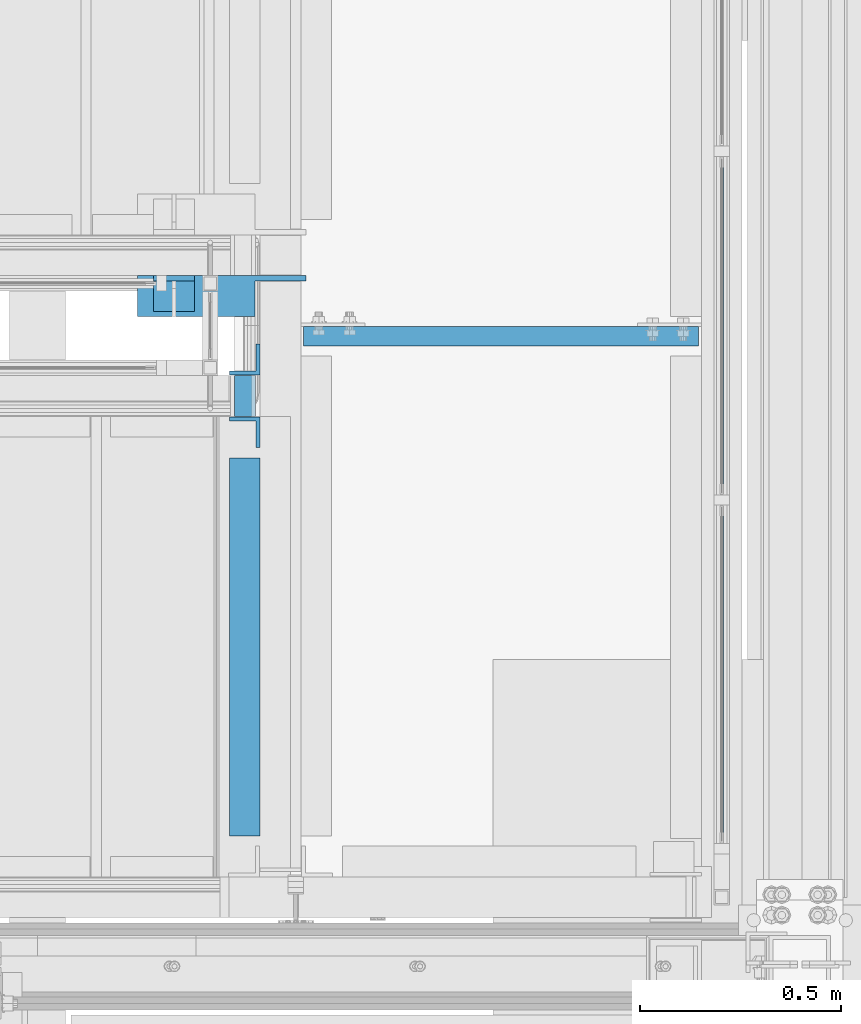
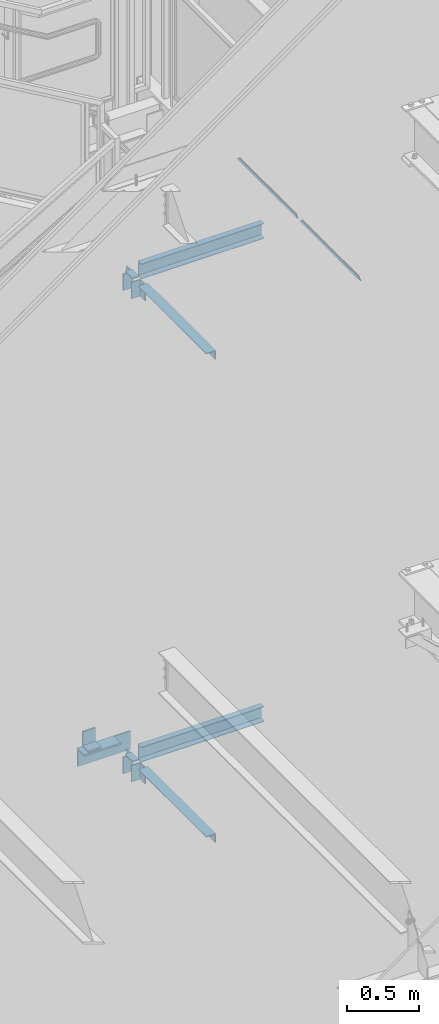
# One storey, part 922 of 1179: 14 beams, 9 elements without a shape of their own.
"""IFC2X3 building model written with IfcOpenShell, lengths in millimetres."""

from ifc_helpers import new_model, si_unit, frame, origin_with_axes, place, context, subcontext, project, spatial, faceted_brep, material, type_object, element, aggregate, save


model = new_model("IFC2X3")

# Units and contexts
model_context = context("Model", 3, precision=1e-05, world=origin_with_axes())
body_context = subcontext(model_context, "Body", "Model", "MODEL_VIEW")
ifc_project = project(units=[si_unit("LENGTHUNIT", "METRE", prefix="MILLI"), si_unit("AREAUNIT", "SQUARE_METRE"), si_unit("VOLUMEUNIT", "CUBIC_METRE"), si_unit("MASSUNIT", "GRAM", prefix="KILO"), si_unit("TIMEUNIT", "SECOND"), si_unit("PLANEANGLEUNIT", "RADIAN"), si_unit("SOLIDANGLEUNIT", "STERADIAN"), si_unit("THERMODYNAMICTEMPERATUREUNIT", "DEGREE_CELSIUS"), si_unit("LUMINOUSINTENSITYUNIT", "LUMEN")], contexts=[model_context])

# Site, building, storey
site_placement = place(None, origin_with_axes())
site = spatial("IfcSite", under=ifc_project, at=site_placement, CompositionType="ELEMENT")
building_placement = place(site_placement, origin_with_axes())
building = spatial("IfcBuilding", under=site, at=building_placement, Name="Undefined", CompositionType="ELEMENT")
storey_placement = place(building_placement, origin_with_axes())
storey = spatial("IfcBuildingStorey", under=building, at=storey_placement, Name="Undefined", CompositionType="ELEMENT", Elevation=0.0)

# Assembly, beams
assembly_1_placement = place(storey_placement, origin_with_axes())
assembly_1 = element("IfcElementAssembly", 1, at=assembly_1_placement, inside=storey, Name="GUARDRAIL", AssemblyPlace="NOTDEFINED", PredefinedType="RIGID_FRAME")
ifc_material_1 = material(Name="STEEL/BUY-OUT")
beam_type_1 = type_object("IfcBeamType", PredefinedType="NOTDEFINED")
beam_1_placement = place(assembly_1_placement, frame((24110.9502052178, 39576.2424575509, 6357.93749958167), z_axis=(0.0, 1.0, 0.0), x_axis=(0.0, 0.0, -1.0)))
beam_1 = element("IfcBeam", 2, at=beam_1_placement, type_object=beam_type_1, material=ifc_material_1, Name="U-EDGE", context=body_context, shape_type="Brep", body=[
    faceted_brep([(-5.45696821063757e-11, -4.76236513509502, -392.906500000157), (22.2249999999613, -4.76236513509502, -415.131500000178), (22.2249999999794, -1.58750000000146, -415.131500000192), (0.0, -1.58750000000146, -392.906500000216), (0.0, 1.58750000000146, -392.906500000216), (25.3999999999969, 1.58750000000146, -418.306499999999), (25.3999999999423, -7.93736513509793, -418.306499999999), (-5.45696821063757e-11, -7.93736513509793, -392.906500000157), (25.3999999999423, -7.93736513509793, 418.306499999999), (-5.45696821063757e-11, -7.93736513509793, 392.906500780409), (-5.45696821063757e-11, -4.76236513509502, 392.906500780409), (22.2249999999613, -4.76236513509502, 415.131500780422), (22.2249999999794, -1.58750000000146, 415.131500780437), (0.0, -1.58750000000146, 392.90650078046), (0.0, 1.58750000000146, 392.90650078046), (25.3999999999969, 1.58750000000146, 418.306499999999)], [[[0, 1, 2, 3, 4, 5, 6, 7]], [[7, 6, 8, 9]], [[0, 7, 9, 10]], [[1, 0, 10, 11]], [[2, 1, 11, 12]], [[3, 2, 12, 13]], [[4, 3, 13, 14]], [[5, 4, 14, 15]], [[6, 5, 15, 8]], [[14, 13, 12, 11, 10, 9, 8, 15]]]),
])
beam_2_placement = place(assembly_1_placement, frame((24110.9502052178, 38710.5257908844, 6357.93750006389), z_axis=(0.0, 1.0, 0.0), x_axis=(0.0, 0.0, -1.0)))
beam_2 = element("IfcBeam", 3, at=beam_2_placement, type_object=beam_type_1, material=ifc_material_1, Name="U-EDGE", context=body_context, shape_type="Brep", body=[
    faceted_brep([(-5.45696821063757e-11, -4.76236513509502, -392.906500000157), (22.2249999999613, -4.76236513509502, -415.131500000178), (22.2249999999794, -1.58750000000146, -415.131500000192), (0.0, -1.58750000000146, -392.906500000216), (0.0, 1.58750000000146, -392.906500000216), (25.3999999999969, 1.58750000000146, -418.306499999999), (25.3999999999423, -7.93736513509793, -418.306499999999), (-5.45696821063757e-11, -7.93736513509793, -392.906500000157), (25.3999999999423, -7.93736513509793, 418.306499999999), (-5.45696821063757e-11, -7.93736513509793, 392.906500780409), (-5.45696821063757e-11, -4.76236513509502, 392.906500780409), (22.2249999999613, -4.76236513509502, 415.131500780422), (22.2249999999794, -1.58750000000146, 415.131500780437), (0.0, -1.58750000000146, 392.90650078046), (0.0, 1.58750000000146, 392.90650078046), (25.3999999999969, 1.58750000000146, 418.306499999999)], [[[0, 1, 2, 3, 4, 5, 6, 7]], [[7, 6, 8, 9]], [[0, 7, 9, 10]], [[1, 0, 10, 11]], [[2, 1, 11, 12]], [[3, 2, 12, 13]], [[4, 3, 13, 14]], [[5, 4, 14, 15]], [[6, 5, 15, 8]], [[14, 13, 12, 11, 10, 9, 8, 15]]]),
])
aggregate(assembly_1, [beam_1, beam_2])

assembly_2_placement = place(storey_placement, origin_with_axes())
assembly_2 = element("IfcElementAssembly", 4, at=assembly_2_placement, inside=storey, Name="BEAM", AssemblyPlace="NOTDEFINED", PredefinedType="RIGID_FRAME")
ifc_material_2 = material(Name="STEEL/A36")
beam_type_2 = type_object("IfcBeamType", Name="L3X3X3/8", PredefinedType="NOTDEFINED")
beam_3_placement = place(assembly_2_placement, frame((22929.8500003381, 39311.2624999755, 6112.47000099707), z_axis=(0.0, -1.0, 0.0), x_axis=(0.0, 0.0, -1.0)))
beam_3 = element("IfcBeam", 5, at=beam_3_placement, type_object=beam_type_2, material=ifc_material_2, Name="ANGLE", ObjectType="L3X3X3/8", context=body_context, shape_type="Brep", body=[
    faceted_brep([(0.0, 38.0999999999985, -38.0999999999999), (0.0, 38.0999999999985, 38.0999999999999), (139.7, 38.0999999999985, 38.0999999999985), (139.7, 38.0999999999985, -38.0999999999985), (0.0, 28.5750000000007, 38.0999999999999), (139.7, 28.5750000000007, 38.0999999999985), (0.0, 28.5750000000007, -28.575), (139.7, 28.5750000000007, -28.5749999999971), (0.0, -38.0999999999985, -28.575), (139.7, -38.0999999999985, -28.5749999999971), (0.0, -38.0999999999985, -38.0999999999999), (139.7, -38.0999999999985, -38.0999999999985)], [[[0, 1, 2, 3]], [[1, 4, 5, 2]], [[4, 6, 7, 5]], [[6, 8, 9, 7]], [[8, 10, 11, 9]], [[10, 0, 3, 11]], [[5, 7, 9, 11, 3, 2]], [[10, 8, 6, 4, 1, 0]]]),
])
beam_4_placement = place(assembly_2_placement, frame((22929.6205004791, 39492.2375000293, 6112.47000099708), z_axis=(-1.0, 0.0, 0.0), x_axis=(0.0, 0.0, -1.0)))
beam_4 = element("IfcBeam", 6, at=beam_4_placement, type_object=beam_type_2, material=ifc_material_2, Name="ANGLE", ObjectType="L3X3X3/8", context=body_context, shape_type="Brep", body=[
    faceted_brep([(0.0, 38.0999999999985, -38.0999999999999), (0.0, 38.0999999999985, 38.0999999999999), (139.7, 38.0999999999985, 38.0999999999985), (139.7, 38.0999999999985, -38.0999999999985), (0.0, 28.5750000000007, 38.0999999999999), (139.7, 28.5750000000007, 38.0999999999985), (0.0, 28.5750000000007, -28.575), (139.7, 28.5750000000007, -28.5749999999971), (0.0, -38.0999999999985, -28.575), (139.7, -38.0999999999985, -28.5749999999971), (0.0, -38.0999999999985, -38.0999999999999), (139.7, -38.0999999999985, -38.0999999999985)], [[[0, 1, 2, 3]], [[1, 4, 5, 2]], [[4, 6, 7, 5]], [[6, 8, 9, 7]], [[8, 10, 11, 9]], [[10, 0, 3, 11]], [[5, 7, 9, 11, 3, 2]], [[10, 8, 6, 4, 1, 0]]]),
])

assembly_3_placement = place(storey_placement, origin_with_axes())
assembly_3 = element("IfcElementAssembly", 7, at=assembly_3_placement, inside=storey, Name="BEAM", AssemblyPlace="NOTDEFINED", PredefinedType="RIGID_FRAME")
beam_5_placement = place(assembly_3_placement, frame((22929.8500003381, 39311.2624999755, 2038.94531200001), z_axis=(0.0, -1.0, 0.0), x_axis=(0.0, 0.0, -1.0)))
beam_5 = element("IfcBeam", 8, at=beam_5_placement, type_object=beam_type_2, material=ifc_material_2, Name="ANGLE", ObjectType="L3X3X3/8", context=body_context, shape_type="Brep", body=[
    faceted_brep([(0.0, 38.0999999999985, -38.0999999999999), (0.0, 38.0999999999985, 38.0999999999999), (139.7, 38.0999999999985, 38.0999999999985), (139.7, 38.0999999999985, -38.0999999999985), (0.0, 28.5750000000007, 38.0999999999999), (139.7, 28.5750000000007, 38.0999999999985), (0.0, 28.5750000000007, -28.575), (139.7, 28.5750000000007, -28.5749999999971), (0.0, -38.0999999999985, -28.575), (139.7, -38.0999999999985, -28.5749999999971), (0.0, -38.0999999999985, -38.0999999999999), (139.7, -38.0999999999985, -38.0999999999985)], [[[0, 1, 2, 3]], [[1, 4, 5, 2]], [[4, 6, 7, 5]], [[6, 8, 9, 7]], [[8, 10, 11, 9]], [[10, 0, 3, 11]], [[5, 7, 9, 11, 3, 2]], [[10, 8, 6, 4, 1, 0]]]),
])
beam_6_placement = place(assembly_3_placement, frame((22929.8500003381, 39492.2375000046, 2038.94531200002), z_axis=(-1.0, 0.0, 0.0), x_axis=(0.0, 0.0, -1.0)))
beam_6 = element("IfcBeam", 9, at=beam_6_placement, type_object=beam_type_2, material=ifc_material_2, Name="ANGLE", ObjectType="L3X3X3/8", context=body_context, shape_type="Brep", body=[
    faceted_brep([(0.0, 38.0999999999985, -38.0999999999999), (0.0, 38.0999999999985, 38.0999999999999), (139.7, 38.0999999999985, 38.0999999999985), (139.7, 38.0999999999985, -38.0999999999985), (0.0, 28.5750000000007, 38.0999999999999), (139.7, 28.5750000000007, 38.0999999999985), (0.0, 28.5750000000007, -28.575), (139.7, 28.5750000000007, -28.5749999999971), (0.0, -38.0999999999985, -28.575), (139.7, -38.0999999999985, -28.5749999999971), (0.0, -38.0999999999985, -38.0999999999999), (139.7, -38.0999999999985, -38.0999999999985)], [[[0, 1, 2, 3]], [[1, 4, 5, 2]], [[4, 6, 7, 5]], [[6, 8, 9, 7]], [[8, 10, 11, 9]], [[10, 0, 3, 11]], [[5, 7, 9, 11, 3, 2]], [[10, 8, 6, 4, 1, 0]]]),
])

# Assembly, beam
assembly_4_placement = place(storey_placement, origin_with_axes())
assembly_4 = element("IfcElementAssembly", 10, at=assembly_4_placement, inside=storey, Name="ANGLE", AssemblyPlace="NOTDEFINED", PredefinedType="RIGID_FRAME")
beam_type_3 = type_object("IfcBeamType", Name="L5X3-1/2X1/2", PredefinedType="NOTDEFINED")
beam_7_placement = place(assembly_4_placement, frame((22703.2939505092, 39655.7500000355, 2115.145312), z_axis=(0.0, 0.0, 1.0), x_axis=(1.0, 0.0, 0.0)))
beam_7 = element("IfcBeam", 11, at=beam_7_placement, type_object=beam_type_3, material=ifc_material_2, Name="ANGLE", ObjectType="L5X3-1/2X1/2", context=body_context, shape_type="Brep", body=[
    faceted_brep([(0.0, 44.4499999999971, -63.5), (0.0, 44.4499999999971, 63.5), (101.599999999999, 44.4499999999971, 63.5), (101.599999999999, 44.4499999999971, -63.5), (0.0, 31.75, 63.5), (101.599999999999, 31.75, 63.5), (0.0, 31.75, -50.8000000000002), (101.599999999999, 31.75, -50.8000000000002), (0.0, -44.4499999999971, -50.8000000000002), (101.599999999999, -44.4499999999971, -50.8000000000002), (0.0, -44.4499999999971, -63.5), (101.599999999999, -44.4499999999971, -63.5)], [[[0, 1, 2, 3]], [[1, 4, 5, 2]], [[4, 6, 7, 5]], [[6, 8, 9, 7]], [[8, 10, 11, 9]], [[10, 0, 3, 11]], [[5, 7, 9, 11, 3, 2]], [[10, 8, 6, 4, 1, 0]]]),
])
aggregate(assembly_4, [beam_7])

assembly_5_placement = place(storey_placement, origin_with_axes())
assembly_5 = element("IfcElementAssembly", 12, at=assembly_5_placement, inside=storey, Name="ANGLE", AssemblyPlace="NOTDEFINED", PredefinedType="RIGID_FRAME")
beam_type_4 = type_object("IfcBeamType", Name="L6X4X1/2", PredefinedType="NOTDEFINED")
beam_8_placement = place(assembly_5_placement, frame((23082.2500006927, 39649.3999999582, 1975.445312), z_axis=(0.0, 0.0, -1.0), x_axis=(-1.0, 0.0, 0.0)))
beam_8 = element("IfcBeam", 13, at=beam_8_placement, type_object=beam_type_4, material=ifc_material_2, Name="ANGLE", ObjectType="L6X4X1/2", context=body_context, shape_type="Brep", body=[
    faceted_brep([(0.0, 38.0999999999985, -63.5), (0.0, 38.0999999999985, -76.1999999999998), (127.0, 38.0999999999985, -76.1999999999998), (127.0, 38.0999999999985, -63.5), (127.0, -50.8000000000029, -63.5), (127.0, -50.8000000000029, -76.1999999999998), (419.099999999999, -50.8000000000029, -76.1999999999998), (419.099999999999, -50.8000000000029, -63.5), (0.0, 50.8000000000029, -76.1999999999998), (419.099999999999, 50.8000000000029, -76.1999999999998), (0.0, 38.0999999999985, 76.1999999999998), (0.0, 50.8000000000029, 76.1999999999998), (127.0, 38.0999999999985, 76.1999999999998), (419.099999999999, 38.0999999999985, 76.1999999999998), (419.099999999999, 50.8000000000029, 76.1999999999998), (419.099999999999, 38.0999999999985, -63.5)], [[[0, 1, 2, 3]], [[4, 3, 2, 5]], [[6, 7, 4, 5]], [[1, 8, 9, 6, 5, 2]], [[10, 11, 8, 1, 0]], [[11, 10, 12, 13, 14]], [[8, 11, 14, 9]], [[13, 15, 7, 6, 9, 14]], [[12, 10, 0, 3, 15, 13]], [[7, 15, 3, 4]]]),
])
aggregate(assembly_5, [beam_8])

# Beam
beam_type_5 = type_object("IfcBeamType", Name="L3X3X1/4", PredefinedType="NOTDEFINED")
beam_9_placement = place(assembly_2_placement, frame((22929.8500003381, 38309.5499999763, 6099.77000099707), z_axis=(0.0, 0.0, -1.0), x_axis=(0.0, 1.0, 0.0)))
beam_9 = element("IfcBeam", 14, at=beam_9_placement, type_object=beam_type_5, material=ifc_material_2, Name="ANGLE", ObjectType="L3X3X1/4", context=body_context, shape_type="Brep", body=[
    faceted_brep([(0.0, 38.0999999999985, -38.0999999999999), (0.0, 38.0999999999985, 38.0999999999999), (938.212500058144, 38.0999999999985, 38.1000000000004), (938.212500058144, 38.0999999999985, -38.1000000000004), (0.0, 31.75, 38.1000000000004), (938.212500058144, 31.75, 38.1000000000004), (0.0, 31.75, -31.75), (938.212500058144, 31.75, -31.75), (0.0, -38.0999999999985, -31.75), (938.212500058144, -38.0999999999985, -31.75), (0.0, -38.0999999999985, -38.0999999999999), (938.212500058144, -38.0999999999985, -38.1000000000004)], [[[0, 1, 2, 3]], [[1, 4, 5, 2]], [[4, 6, 7, 5]], [[6, 8, 9, 7]], [[8, 10, 11, 9]], [[10, 0, 3, 11]], [[5, 7, 9, 11, 3, 2]], [[10, 8, 6, 4, 1, 0]]]),
])

aggregate(assembly_2, [beam_9, beam_3, beam_4])

beam_10_placement = place(assembly_3_placement, frame((22929.8500003381, 38309.5499999763, 2026.245312), z_axis=(0.0, 0.0, -1.0), x_axis=(0.0, 1.0, 0.0)))
beam_10 = element("IfcBeam", 15, at=beam_10_placement, type_object=beam_type_5, material=ifc_material_2, Name="ANGLE", ObjectType="L3X3X1/4", context=body_context, shape_type="Brep", body=[
    faceted_brep([(0.0, 38.0999999999985, -38.0999999999999), (0.0, 38.0999999999985, 38.0999999999999), (938.212500058144, 38.0999999999985, 38.1000000000004), (938.212500058144, 38.0999999999985, -38.1000000000004), (0.0, 31.75, 38.1000000000004), (938.212500058144, 31.75, 38.1000000000004), (0.0, 31.75, -31.75), (938.212500058144, 31.75, -31.75), (0.0, -38.0999999999985, -31.75), (938.212500058144, -38.0999999999985, -31.75), (0.0, -38.0999999999985, -38.0999999999999), (938.212500058144, -38.0999999999985, -38.1000000000004)], [[[0, 1, 2, 3]], [[1, 4, 5, 2]], [[4, 6, 7, 5]], [[6, 8, 9, 7]], [[8, 10, 11, 9]], [[10, 0, 3, 11]], [[5, 7, 9, 11, 3, 2]], [[10, 8, 6, 4, 1, 0]]]),
])

aggregate(assembly_3, [beam_10, beam_5, beam_6])

# Assembly, beam
assembly_6_placement = place(storey_placement, origin_with_axes())
assembly_6 = element("IfcElementAssembly", 16, at=assembly_6_placement, inside=storey, Name="STAIR", AssemblyPlace="NOTDEFINED", PredefinedType="RIGID_FRAME")
beam_type_6 = type_object("IfcBeamType", PredefinedType="NOTDEFINED")
beam_11_placement = place(assembly_6_placement, frame((22956.8374995998, 39401.7499999899, 6133.10750099708), z_axis=(0.0, -1.0, 0.0), x_axis=(-1.0, 0.0, 0.0)))
beam_11 = element("IfcBeam", 17, at=beam_11_placement, type_object=beam_type_6, material=ifc_material_2, Name="PLATE", context=body_context, shape_type="Brep", body=[
    faceted_brep([(0.0, 4.76249999999982, -50.7999999999993), (0.0, 4.76249999999982, 50.7999999999993), (52.3874995939332, 4.76249999999982, 50.8000000000029), (52.3874995939332, 4.76249999999982, -50.8000000000029), (0.0, -4.76249999999982, 50.7999999999993), (52.3874995939332, -4.76249999999982, 50.8000000000029), (0.0, -4.76249999999982, -50.7999999999993), (52.3874995939332, -4.76249999999982, -50.8000000000029)], [[[0, 1, 2, 3]], [[1, 4, 5, 2]], [[4, 6, 7, 5]], [[6, 0, 3, 7]], [[5, 7, 3, 2]], [[6, 4, 1, 0]]]),
])
aggregate(assembly_6, [beam_11])

assembly_7_placement = place(storey_placement, origin_with_axes())
assembly_7 = element("IfcElementAssembly", 18, at=assembly_7_placement, inside=storey, Name="STAIR", AssemblyPlace="NOTDEFINED", PredefinedType="RIGID_FRAME")
beam_12_placement = place(assembly_7_placement, frame((22956.8374998743, 39401.7499999987, 2059.58281200001), z_axis=(0.0, -1.0, 0.0), x_axis=(-1.0, 0.0, 0.0)))
beam_12 = element("IfcBeam", 19, at=beam_12_placement, type_object=beam_type_6, material=ifc_material_2, Name="PLATE", context=body_context, shape_type="Brep", body=[
    faceted_brep([(0.0, 4.76249999999982, -50.7999999999993), (0.0, 4.76249999999982, 50.7999999999993), (52.3874995939332, 4.76249999999982, 50.8000000000029), (52.3874995939332, 4.76249999999982, -50.8000000000029), (0.0, -4.76249999999982, 50.7999999999993), (52.3874995939332, -4.76249999999982, 50.8000000000029), (0.0, -4.76249999999982, -50.7999999999993), (52.3874995939332, -4.76249999999982, -50.8000000000029)], [[[0, 1, 2, 3]], [[1, 4, 5, 2]], [[4, 6, 7, 5]], [[6, 0, 3, 7]], [[5, 7, 3, 2]], [[6, 4, 1, 0]]]),
])
aggregate(assembly_7, [beam_12])

assembly_8_placement = place(storey_placement, origin_with_axes())
assembly_8 = element("IfcElementAssembly", 20, at=assembly_8_placement, inside=storey, Name="BEAM", AssemblyPlace="NOTDEFINED", PredefinedType="RIGID_FRAME")
beam_type_7 = type_object("IfcBeamType", Name="C5X9", PredefinedType="NOTDEFINED")
beam_13_placement = place(assembly_8_placement, frame((23069.5499999238, 39549.784375, 6026.15), z_axis=(0.0, 0.0, 1.0), x_axis=(1.0, 0.0, 0.0)))
beam_13 = element("IfcBeam", 21, at=beam_13_placement, type_object=beam_type_7, material=ifc_material_2, Name="BEAM", ObjectType="C5X9", context=body_context, shape_type="Brep", body=[
    faceted_brep([(6.35000000080618, 23.8125, -63.5), (6.35000000080618, 23.8125, 63.5), (987.425000076193, 23.8125, 63.5), (987.425000076193, 23.8125, -63.5), (6.35000000080618, -23.8125, 63.5), (987.425000076193, -23.8125, 63.5), (6.35000000080618, -23.8125, 59.5296625000001), (987.425000076193, -23.8125, 59.5296625000001), (6.35000000080618, 15.875, 52.9177250000002), (987.425000076193, 15.875, 52.9177250000002), (6.35000000080618, 15.875, -52.9177249999998), (987.425000076193, 15.875, -52.9177250000002), (6.35000000080618, -23.8125, -59.5296625000001), (987.425000076193, -23.8125, -59.5296625000001), (6.35000000080618, -23.8125, -63.5), (987.425000076193, -23.8125, -63.5)], [[[0, 1, 2, 3]], [[1, 4, 5, 2]], [[4, 6, 7, 5]], [[6, 8, 9, 7]], [[8, 10, 11, 9]], [[10, 12, 13, 11]], [[12, 14, 15, 13]], [[14, 0, 3, 15]], [[5, 7, 9, 11, 13, 15, 3, 2]], [[14, 12, 10, 8, 6, 4, 1, 0]]]),
])
aggregate(assembly_8, [beam_13])

assembly_9_placement = place(storey_placement, origin_with_axes())
assembly_9 = element("IfcElementAssembly", 22, at=assembly_9_placement, inside=storey, Name="BEAM", AssemblyPlace="NOTDEFINED", PredefinedType="RIGID_FRAME")
beam_14_placement = place(assembly_9_placement, frame((23069.5500003381, 39549.784375, 1952.625), z_axis=(0.0, 0.0, 1.0), x_axis=(1.0, 0.0, 0.0)))
beam_14 = element("IfcBeam", 23, at=beam_14_placement, type_object=beam_type_7, material=ifc_material_2, Name="BEAM", ObjectType="C5X9", context=body_context, shape_type="Brep", body=[
    faceted_brep([(6.35000000080618, 23.8125, -63.5), (6.35000000080618, 23.8125, 63.5), (987.425000076193, 23.8125, 63.5), (987.425000076193, 23.8125, -63.5), (6.35000000080618, -23.8125, 63.5), (987.425000076193, -23.8125, 63.5), (6.35000000080618, -23.8125, 59.5296625000001), (987.425000076193, -23.8125, 59.5296625000001), (6.35000000080618, 15.875, 52.9177250000002), (987.425000076193, 15.875, 52.9177250000002), (6.35000000080618, 15.875, -52.9177249999998), (987.425000076193, 15.875, -52.9177250000002), (6.35000000080618, -23.8125, -59.5296625000001), (987.425000076193, -23.8125, -59.5296625000001), (6.35000000080618, -23.8125, -63.5), (987.425000076193, -23.8125, -63.5)], [[[0, 1, 2, 3]], [[1, 4, 5, 2]], [[4, 6, 7, 5]], [[6, 8, 9, 7]], [[8, 10, 11, 9]], [[10, 12, 13, 11]], [[12, 14, 15, 13]], [[14, 0, 3, 15]], [[5, 7, 9, 11, 13, 15, 3, 2]], [[14, 12, 10, 8, 6, 4, 1, 0]]]),
])
aggregate(assembly_9, [beam_14])

save(model, "model.ifc")
